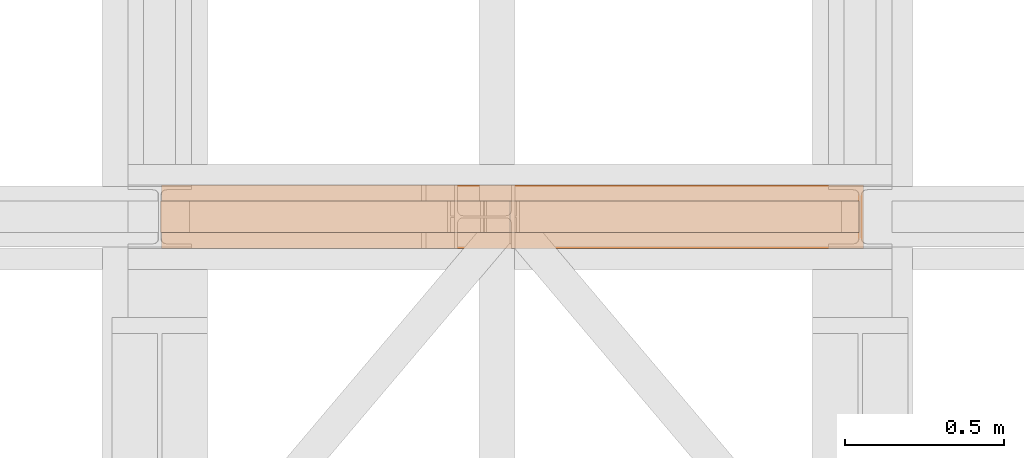
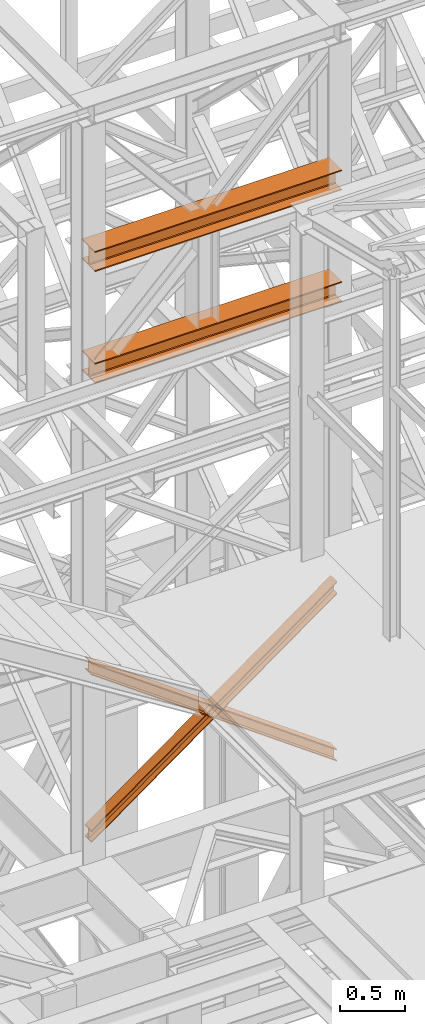
# One storey, part 109 of 208: 4 proxies.
"""IFC2X3 building model written with IfcOpenShell, lengths in millimetres."""

from ifc_helpers import new_model, entity, si_unit, converted_unit, frame, origin, origin_with_axes, place, context, subcontext, project, spatial, faceted_brep, element, save


model = new_model("IFC2X3")

# Units and contexts
model_context = context("Model", 3, precision=1e-05, world=origin())
plan_context = context("Plan", 3, precision=1e-05, world=origin())
body_context = subcontext(model_context, "Body", "Model", "MODEL_VIEW")
ifc_project = project(units=[si_unit("LENGTHUNIT", "METRE", prefix="MILLI"), converted_unit("PLANEANGLEUNIT", "DEGREE", entity("IfcPlaneAngleMeasure", 0.0174532925199433), si_unit("PLANEANGLEUNIT", "RADIAN"), dimensions=[0, 0, 0, 0, 0, 0, 0]), si_unit("AREAUNIT", "SQUARE_METRE"), si_unit("VOLUMEUNIT", "CUBIC_METRE")], contexts=[model_context, plan_context])

# Building, storey
building_placement = place(None, origin())
building = spatial("IfcBuilding", under=ifc_project, at=building_placement, CompositionType="COMPLEX")
storey_placement = place(building_placement, origin_with_axes())
storey = spatial("IfcBuildingStorey", under=building, at=storey_placement, Name="Geschoss", CompositionType="ELEMENT")

# Proxies
proxy_1_placement = place(storey_placement, frame((-4.245031471322136, -16012.57439031789, 5434.990005364418), z_axis=(0.0, 0.0, 1.0), x_axis=(1.0, 0.0, 0.0)))
element("IfcBuildingElementProxy", 1, at=proxy_1_placement, inside=storey, context=body_context, shape_type="Brep", body=[
    faceted_brep([(2194.25999993293, 0.01000000000021828, 1583.81921929576), (0.009999999999990905, 0.01000000000021828, 0.01000000000112777), (0.009999999999990905, 0.01000000000021828, 9.69256505868816), (2194.25999993293, 0.01000000000021828, 1593.501784354445), (2194.25999993293, 100.0100000000002, 1583.819219295759), (0.009999999999990905, 100.0100000000002, 0.01000000000021828), (0.009999999999990905, 0.01000000000021828, 0.01000000000112777), (2194.25999993293, 0.01000000000021828, 1583.81921929576), (2194.25999993293, 100.0100000000002, 1593.501784354445), (0.009999999999990905, 100.0100000000002, 9.69256505868816), (0.009999999999990905, 100.0100000000002, 0.01000000000021828), (2194.25999993293, 100.0100000000002, 1583.819219295759), (2194.25999993293, 52.51000000000022, 1593.501784354445), (0.009999999999990905, 52.51000000000022, 9.69256505868816), (0.009999999999990905, 100.0100000000002, 9.69256505868816), (2194.25999993293, 100.0100000000002, 1593.501784354445), (2194.259999932929, 52.51000000000022, 1690.327434941312), (0.009999999999990905, 52.51000000000022, 106.5182156455558), (0.009999999999990905, 52.51000000000022, 9.69256505868816), (2194.25999993293, 52.51000000000022, 1593.501784354445), (2194.25999993293, 100.0100000000002, 1690.327434941312), (0.01000000000180989, 100.0100000000002, 106.5182156455558), (0.009999999999990905, 52.51000000000022, 106.5182156455558), (2194.259999932929, 52.51000000000022, 1690.327434941312), (2194.25999993293, 100.0100000000002, 1700.01), (0.009999999999990905, 100.0100000000002, 116.2007807042428), (0.01000000000180989, 100.0100000000002, 106.5182156455558), (2194.25999993293, 100.0100000000002, 1690.327434941312), (2194.259999932929, 0.01000000000021828, 1700.01), (0.009999999999990905, 0.01000000000021828, 116.2007807042428), (0.009999999999990905, 100.0100000000002, 116.2007807042428), (2194.25999993293, 100.0100000000002, 1700.01), (2194.25999993293, 0.01000000000021828, 1690.327434941312), (0.009999999999990905, 0.01000000000021828, 106.5182156455549), (0.009999999999990905, 0.01000000000021828, 116.2007807042428), (2194.259999932929, 0.01000000000021828, 1700.01), (2194.25999993293, 47.51000000000022, 1690.327434941311), (0.009999999999990905, 47.51000000000022, 106.5182156455549), (0.009999999999990905, 0.01000000000021828, 106.5182156455549), (2194.25999993293, 0.01000000000021828, 1690.327434941312), (2194.25999993293, 47.51000000000022, 1593.501784354445), (0.009999999999990905, 47.51000000000022, 9.69256505868816), (0.009999999999990905, 47.51000000000022, 106.5182156455549), (2194.25999993293, 47.51000000000022, 1690.327434941311), (2194.25999993293, 0.01000000000021828, 1593.501784354445), (0.009999999999990905, 0.01000000000021828, 9.69256505868816), (0.009999999999990905, 47.51000000000022, 9.69256505868816), (2194.25999993293, 47.51000000000022, 1593.501784354445), (2194.25999993293, 0.01000000000021828, 1593.501784354445), (2194.25999993293, 47.51000000000022, 1593.501784354445), (2194.25999993293, 47.51000000000022, 1690.327434941311), (2194.25999993293, 0.01000000000021828, 1690.327434941312), (2194.259999932929, 0.01000000000021828, 1700.01), (2194.25999993293, 100.0100000000002, 1700.01), (2194.25999993293, 100.0100000000002, 1690.327434941312), (2194.259999932929, 52.51000000000022, 1690.327434941312), (2194.25999993293, 52.51000000000022, 1593.501784354445), (2194.25999993293, 100.0100000000002, 1593.501784354445), (2194.25999993293, 100.0100000000002, 1583.819219295759), (2194.25999993293, 0.01000000000021828, 1583.81921929576), (0.009999999999990905, 0.01000000000021828, 0.01000000000112777), (0.009999999999990905, 100.0100000000002, 0.01000000000021828), (0.009999999999990905, 100.0100000000002, 9.69256505868816), (0.009999999999990905, 52.51000000000022, 9.69256505868816), (0.009999999999990905, 52.51000000000022, 106.5182156455558), (0.01000000000180989, 100.0100000000002, 106.5182156455558), (0.009999999999990905, 100.0100000000002, 116.2007807042428), (0.009999999999990905, 0.01000000000021828, 116.2007807042428), (0.009999999999990905, 0.01000000000021828, 106.5182156455549), (0.009999999999990905, 47.51000000000022, 106.5182156455549), (0.009999999999990905, 47.51000000000022, 9.69256505868816), (0.009999999999990905, 0.01000000000021828, 9.69256505868816)], [[[0, 1, 2, 3]], [[4, 5, 6, 7]], [[8, 9, 10, 11]], [[12, 13, 14, 15]], [[16, 17, 18, 19]], [[20, 21, 22, 23]], [[24, 25, 26, 27]], [[28, 29, 30, 31]], [[32, 33, 34, 35]], [[36, 37, 38, 39]], [[40, 41, 42, 43]], [[44, 45, 46, 47]], [[48, 49, 50, 51, 52, 53, 54, 55, 56, 57, 58, 59]], [[60, 61, 62, 63, 64, 65, 66, 67, 68, 69, 70, 71]]], orient=[[False], [False], [False], [False], [False], [False], [False], [False], [False], [False], [False], [False], [False], [False]]),
])
proxy_2_placement = place(storey_placement, frame((-4.245031471322136, -16012.57439031789, 5434.990005364418), z_axis=(0.0, 0.0, 1.0), x_axis=(1.0, 0.0, 0.0)))
element("IfcBuildingElementProxy", 2, at=proxy_2_placement, inside=storey, context=body_context, shape_type="Brep", body=[
    faceted_brep([(0.009999999999990905, 0.01000000000021828, 1593.501784354445), (2194.25999993293, 0.01000000000021828, 9.692565058686341), (2194.25999993293, 0.01000000000021828, 0.01000000000112777), (0.009999999999990905, 0.01000000000021828, 1583.819219295759), (0.009999999999990905, 0.01000000000021828, 1583.819219295759), (2194.25999993293, 0.01000000000021828, 0.01000000000112777), (2194.25999993293, 100.0100000000002, 0.01000000000021828), (0.009999999999990905, 100.0100000000002, 1583.819219295759), (0.009999999999990905, 100.0100000000002, 1583.819219295759), (2194.25999993293, 100.0100000000002, 0.01000000000021828), (2194.25999993293, 100.0100000000002, 9.692565058686341), (0.009999999999990905, 100.0100000000002, 1593.501784354445), (0.009999999999990905, 100.0100000000002, 1593.501784354445), (2194.25999993293, 100.0100000000002, 9.692565058686341), (2194.25999993293, 52.51000000000022, 9.692565058686341), (0.009999999999990905, 52.51000000000022, 1593.501784354445), (0.009999999999990905, 52.51000000000022, 1593.501784354445), (2194.25999993293, 52.51000000000022, 9.692565058686341), (2194.259999932929, 52.51000000000022, 106.5182156455549), (0.009999999999990905, 52.51000000000022, 1690.327434941313), (0.009999999999990905, 52.51000000000022, 1690.327434941313), (2194.259999932929, 52.51000000000022, 106.5182156455549), (2194.25999993293, 100.0100000000002, 106.5182156455549), (0.009999999999990905, 100.0100000000002, 1690.327434941311), (0.009999999999990905, 100.0100000000002, 1690.327434941311), (2194.25999993293, 100.0100000000002, 106.5182156455549), (2194.259999932929, 100.0100000000002, 116.2007807042419), (0.009999999999990905, 100.0100000000002, 1700.01), (0.009999999999990905, 100.0100000000002, 1700.01), (2194.259999932929, 100.0100000000002, 116.2007807042419), (2194.25999993293, 0.01000000000021828, 116.2007807042419), (0.009999999999990905, 0.01000000000021828, 1700.01), (0.009999999999990905, 0.01000000000021828, 1700.01), (2194.25999993293, 0.01000000000021828, 116.2007807042419), (2194.25999993293, 0.01000000000021828, 106.5182156455549), (0.009999999999990905, 0.01000000000021828, 1690.327434941313), (0.009999999999990905, 0.01000000000021828, 1690.327434941313), (2194.25999993293, 0.01000000000021828, 106.5182156455549), (2194.25999993293, 47.51000000000022, 106.5182156455539), (0.009999999999990905, 47.51000000000022, 1690.327434941311), (0.009999999999990905, 47.51000000000022, 1690.327434941311), (2194.25999993293, 47.51000000000022, 106.5182156455539), (2194.25999993293, 47.51000000000022, 9.692565058686341), (0.009999999999990905, 47.51000000000022, 1593.501784354445), (0.009999999999990905, 47.51000000000022, 1593.501784354445), (2194.25999993293, 47.51000000000022, 9.692565058686341), (2194.25999993293, 0.01000000000021828, 9.692565058686341), (0.009999999999990905, 0.01000000000021828, 1593.501784354445), (2194.25999993293, 0.01000000000021828, 9.692565058686341), (2194.25999993293, 47.51000000000022, 9.692565058686341), (2194.25999993293, 47.51000000000022, 106.5182156455539), (2194.25999993293, 0.01000000000021828, 106.5182156455549), (2194.25999993293, 0.01000000000021828, 116.2007807042419), (2194.259999932929, 100.0100000000002, 116.2007807042419), (2194.25999993293, 100.0100000000002, 106.5182156455549), (2194.259999932929, 52.51000000000022, 106.5182156455549), (2194.25999993293, 52.51000000000022, 9.692565058686341), (2194.25999993293, 100.0100000000002, 9.692565058686341), (2194.25999993293, 100.0100000000002, 0.01000000000021828), (2194.25999993293, 0.01000000000021828, 0.01000000000112777), (0.009999999999990905, 0.01000000000021828, 1583.819219295759), (0.009999999999990905, 100.0100000000002, 1583.819219295759), (0.009999999999990905, 100.0100000000002, 1593.501784354445), (0.009999999999990905, 52.51000000000022, 1593.501784354445), (0.009999999999990905, 52.51000000000022, 1690.327434941313), (0.009999999999990905, 100.0100000000002, 1690.327434941311), (0.009999999999990905, 100.0100000000002, 1700.01), (0.009999999999990905, 0.01000000000021828, 1700.01), (0.009999999999990905, 0.01000000000021828, 1690.327434941313), (0.009999999999990905, 47.51000000000022, 1690.327434941311), (0.009999999999990905, 47.51000000000022, 1593.501784354445), (0.009999999999990905, 0.01000000000021828, 1593.501784354445)], [[[0, 1, 2, 3]], [[4, 5, 6, 7]], [[8, 9, 10, 11]], [[12, 13, 14, 15]], [[16, 17, 18, 19]], [[20, 21, 22, 23]], [[24, 25, 26, 27]], [[28, 29, 30, 31]], [[32, 33, 34, 35]], [[36, 37, 38, 39]], [[40, 41, 42, 43]], [[44, 45, 46, 47]], [[48, 49, 50, 51, 52, 53, 54, 55, 56, 57, 58, 59]], [[60, 61, 62, 63, 64, 65, 66, 67, 68, 69, 70, 71]]], orient=[[False], [False], [False], [False], [False], [False], [False], [False], [False], [False], [False], [False], [False], [False]]),
])
proxy_3_placement = place(storey_placement, frame((-1.630483097365641, -16062.574391808, 10858.99004617683), z_axis=(0.0, 0.0, 1.0), x_axis=(1.0, 0.0, 0.0)))
element("IfcBuildingElementProxy", 3, at=proxy_3_placement, inside=storey, context=body_context, shape_type="Brep", body=[
    faceted_brep([(0.009999999999990905, 0.01000000000021828, 0.01000000000021828), (0.009999999999990905, 200.0100029802325, 0.01000000000021828), (0.009999999999990905, 200.0100029802325, 10.00999791383765), (0.009999999999990905, 121.2600035762789, 10.01000536441825), (0.009999999999990905, 111.9441915473344, 11.87455041170142), (0.009999999999990905, 105.1245498640838, 18.69419349193595), (0.009999999999990905, 103.2600015571716, 28.01000458955787), (0.009999999999990905, 103.2600015571716, 162.0100153779986), (0.009999999999990905, 105.1245498640838, 171.3258264756205), (0.009999999999990905, 111.9441915473344, 178.145469555855), (0.009999999999990905, 121.2600035762789, 180.0100146031382), (0.009999999999990905, 200.0100029802325, 180.0100146031382), (0.009999999999990905, 200.0100029802325, 190.0100125169756), (0.009999999999990905, 0.01000000000021828, 190.0100125169756), (0.009999999999990905, 0.01000000000021828, 180.0100146031382), (0.009999999999990905, 78.75999940395377, 180.0100146031382), (0.009999999999990905, 88.07581143289826, 178.145469555855), (0.009999999999990905, 94.89545311614893, 171.3258264756205), (0.009999999999990905, 96.76000142306111, 162.0100153779986), (0.009999999999990905, 96.76000142306111, 28.01000458955787), (0.009999999999990905, 94.89545311614893, 18.69419349193595), (0.009999999999990905, 88.07581143289826, 11.87455041170142), (0.009999999999990905, 78.75999940395377, 10.01000536441825), (0.009999999999990905, 0.01000000000021828, 10.00999791383765), (0.009999999999990905, 200.0100029802325, 0.01000000000021828), (0.009999999999990905, 0.01000000000021828, 0.01000000000021828), (2205.009999999998, 0.00999999999839929, 0.01000000000021828), (2205.009999999998, 200.0100029802306, 0.01000000000021828), (0.009999999999990905, 200.0100029802325, 10.00999791383765), (0.009999999999990905, 200.0100029802325, 0.01000000000021828), (2205.009999999998, 200.0100029802306, 0.01000000000021828), (2205.009999999998, 200.0100029802306, 10.00999791383765), (0.009999999999990905, 121.2600035762789, 10.01000536441825), (0.009999999999990905, 200.0100029802325, 10.00999791383765), (2205.009999999998, 200.0100029802306, 10.00999791383765), (2205.009999999998, 121.2600035762771, 10.01000536441825), (0.009999999999990905, 111.9441915473344, 11.87455041170142), (0.009999999999990905, 121.2600035762789, 10.01000536441825), (2205.009999999998, 121.2600035762771, 10.01000536441825), (2205.009999999998, 111.9441915473326, 11.87455041170142), (0.009999999999990905, 105.1245498640838, 18.69419349193595), (0.009999999999990905, 111.9441915473344, 11.87455041170142), (2205.009999999998, 111.9441915473326, 11.87455041170142), (2205.009999999998, 105.1245498640819, 18.69419349193595), (0.009999999999990905, 103.2600015571716, 28.01000458955787), (0.009999999999990905, 105.1245498640838, 18.69419349193595), (2205.009999999998, 105.1245498640819, 18.69419349193595), (2205.009999999998, 103.2600015571697, 28.01000458955787), (0.009999999999990905, 103.2600015571716, 162.0100153779986), (0.009999999999990905, 103.2600015571716, 28.01000458955787), (2205.009999999998, 103.2600015571697, 28.01000458955787), (2205.009999999998, 103.2600015571697, 162.0100153779986), (0.009999999999990905, 105.1245498640838, 171.3258264756205), (0.009999999999990905, 103.2600015571716, 162.0100153779986), (2205.009999999998, 103.2600015571697, 162.0100153779986), (2205.009999999998, 105.1245498640819, 171.3258264756205), (0.009999999999990905, 111.9441915473344, 178.145469555855), (0.009999999999990905, 105.1245498640838, 171.3258264756205), (2205.009999999998, 105.1245498640819, 171.3258264756205), (2205.009999999998, 111.9441915473326, 178.145469555855), (0.009999999999990905, 121.2600035762789, 180.0100146031382), (0.009999999999990905, 111.9441915473344, 178.145469555855), (2205.009999999998, 111.9441915473326, 178.145469555855), (2205.009999999998, 121.2600035762771, 180.0100146031382), (0.009999999999990905, 200.0100029802325, 180.0100146031382), (0.009999999999990905, 121.2600035762789, 180.0100146031382), (2205.009999999998, 121.2600035762771, 180.0100146031382), (2205.009999999998, 200.0100029802306, 180.0100146031382), (0.009999999999990905, 200.0100029802325, 190.0100125169756), (0.009999999999990905, 200.0100029802325, 180.0100146031382), (2205.009999999998, 200.0100029802306, 180.0100146031382), (2205.009999999998, 200.0100029802306, 190.0100125169756), (0.009999999999990905, 0.01000000000021828, 190.0100125169756), (0.009999999999990905, 200.0100029802325, 190.0100125169756), (2205.009999999998, 200.0100029802306, 190.0100125169756), (2205.009999999998, 0.00999999999839929, 190.0100125169756), (0.009999999999990905, 0.01000000000021828, 180.0100146031382), (0.009999999999990905, 0.01000000000021828, 190.0100125169756), (2205.009999999998, 0.00999999999839929, 190.0100125169756), (2205.009999999998, 0.00999999999839929, 180.0100146031382), (0.009999999999990905, 78.75999940395377, 180.0100146031382), (0.009999999999990905, 0.01000000000021828, 180.0100146031382), (2205.009999999998, 0.00999999999839929, 180.0100146031382), (2205.009999999998, 78.75999940395195, 180.0100146031382), (0.009999999999990905, 88.07581143289826, 178.145469555855), (0.009999999999990905, 78.75999940395377, 180.0100146031382), (2205.009999999998, 78.75999940395195, 180.0100146031382), (2205.009999999998, 88.07581143289644, 178.145469555855), (0.009999999999990905, 94.89545311614893, 171.3258264756205), (0.009999999999990905, 88.07581143289826, 178.145469555855), (2205.009999999998, 88.07581143289644, 178.145469555855), (2205.009999999998, 94.89545311614711, 171.3258264756205), (0.009999999999990905, 96.76000142306111, 162.0100153779986), (0.009999999999990905, 94.89545311614893, 171.3258264756205), (2205.009999999998, 94.89545311614711, 171.3258264756205), (2205.009999999998, 96.7600014230593, 162.0100153779986), (0.009999999999990905, 96.76000142306111, 28.01000458955787), (0.009999999999990905, 96.76000142306111, 162.0100153779986), (2205.009999999998, 96.7600014230593, 162.0100153779986), (2205.009999999998, 96.7600014230593, 28.01000458955787), (0.009999999999990905, 94.89545311614893, 18.69419349193595), (0.009999999999990905, 96.76000142306111, 28.01000458955787), (2205.009999999998, 96.7600014230593, 28.01000458955787), (2205.009999999998, 94.89545311614711, 18.69419349193595), (0.009999999999990905, 88.07581143289826, 11.87455041170142), (0.009999999999990905, 94.89545311614893, 18.69419349193595), (2205.009999999998, 94.89545311614711, 18.69419349193595), (2205.009999999998, 88.07581143289644, 11.87455041170142), (0.009999999999990905, 78.75999940395377, 10.01000536441825), (0.009999999999990905, 88.07581143289826, 11.87455041170142), (2205.009999999998, 88.07581143289644, 11.87455041170142), (2205.009999999998, 78.75999940395195, 10.01000536441825), (0.009999999999990905, 0.01000000000021828, 10.00999791383765), (0.009999999999990905, 78.75999940395377, 10.01000536441825), (2205.009999999998, 78.75999940395195, 10.01000536441825), (2205.009999999998, 0.00999999999839929, 10.00999791383765), (0.009999999999990905, 0.01000000000021828, 0.01000000000021828), (0.009999999999990905, 0.01000000000021828, 10.00999791383765), (2205.009999999998, 0.00999999999839929, 10.00999791383765), (2205.009999999998, 0.00999999999839929, 0.01000000000021828), (2205.009999999998, 0.00999999999839929, 0.01000000000021828), (2205.009999999998, 0.00999999999839929, 10.00999791383765), (2205.009999999998, 78.75999940395195, 10.01000536441825), (2205.009999999998, 88.07581143289644, 11.87455041170142), (2205.009999999998, 94.89545311614711, 18.69419349193595), (2205.009999999998, 96.7600014230593, 28.01000458955787), (2205.009999999998, 96.7600014230593, 162.0100153779986), (2205.009999999998, 94.89545311614711, 171.3258264756205), (2205.009999999998, 88.07581143289644, 178.145469555855), (2205.009999999998, 78.75999940395195, 180.0100146031382), (2205.009999999998, 0.00999999999839929, 180.0100146031382), (2205.009999999998, 0.00999999999839929, 190.0100125169756), (2205.009999999998, 200.0100029802306, 190.0100125169756), (2205.009999999998, 200.0100029802306, 180.0100146031382), (2205.009999999998, 121.2600035762771, 180.0100146031382), (2205.009999999998, 111.9441915473326, 178.145469555855), (2205.009999999998, 105.1245498640819, 171.3258264756205), (2205.009999999998, 103.2600015571697, 162.0100153779986), (2205.009999999998, 103.2600015571697, 28.01000458955787), (2205.009999999998, 105.1245498640819, 18.69419349193595), (2205.009999999998, 111.9441915473326, 11.87455041170142), (2205.009999999998, 121.2600035762771, 10.01000536441825), (2205.009999999998, 200.0100029802306, 10.00999791383765), (2205.009999999998, 200.0100029802306, 0.01000000000021828)], [[[0, 1, 2, 3, 4, 5, 6, 7, 8, 9, 10, 11, 12, 13, 14, 15, 16, 17, 18, 19, 20, 21, 22, 23]], [[24, 25, 26, 27]], [[28, 29, 30, 31]], [[32, 33, 34, 35]], [[36, 37, 38, 39]], [[40, 41, 42, 43]], [[44, 45, 46, 47]], [[48, 49, 50, 51]], [[52, 53, 54, 55]], [[56, 57, 58, 59]], [[60, 61, 62, 63]], [[64, 65, 66, 67]], [[68, 69, 70, 71]], [[72, 73, 74, 75]], [[76, 77, 78, 79]], [[80, 81, 82, 83]], [[84, 85, 86, 87]], [[88, 89, 90, 91]], [[92, 93, 94, 95]], [[96, 97, 98, 99]], [[100, 101, 102, 103]], [[104, 105, 106, 107]], [[108, 109, 110, 111]], [[112, 113, 114, 115]], [[116, 117, 118, 119]], [[120, 121, 122, 123, 124, 125, 126, 127, 128, 129, 130, 131, 132, 133, 134, 135, 136, 137, 138, 139, 140, 141, 142, 143]]], orient=[[False], [False], [False], [False], [False], [False], [False], [False], [False], [False], [False], [False], [False], [False], [False], [False], [False], [False], [False], [False], [False], [False], [False], [False], [False], [False]]),
])
proxy_4_placement = place(storey_placement, frame((-1.630483097365641, -16062.574391808, 9803.990033659858), z_axis=(0.0, 0.0, 1.0), x_axis=(1.0, 0.0, 0.0)))
element("IfcBuildingElementProxy", 4, at=proxy_4_placement, inside=storey, context=body_context, shape_type="Brep", body=[
    faceted_brep([(0.009999999999990905, 0.01000000000021828, 0.01000000000021828), (0.009999999999990905, 200.0100029802325, 0.01000000000021828), (0.009999999999990905, 200.0100029802325, 10.00999791383765), (0.009999999999990905, 121.2600035762789, 10.01000536441825), (0.009999999999990905, 111.9441915473344, 11.87455041170142), (0.009999999999990905, 105.1245498640838, 18.69419349193595), (0.009999999999990905, 103.2600015571716, 28.01000458955787), (0.009999999999990905, 103.2600015571716, 162.0100153779986), (0.009999999999990905, 105.1245498640838, 171.3258264756205), (0.009999999999990905, 111.9441915473344, 178.145469555855), (0.009999999999990905, 121.2600035762789, 180.0100146031382), (0.009999999999990905, 200.0100029802325, 180.0100146031382), (0.009999999999990905, 200.0100029802325, 190.0100125169756), (0.009999999999990905, 0.01000000000021828, 190.0100125169756), (0.009999999999990905, 0.01000000000021828, 180.0100146031382), (0.009999999999990905, 78.75999940395377, 180.0100146031382), (0.009999999999990905, 88.07581143289826, 178.145469555855), (0.009999999999990905, 94.89545311614893, 171.3258264756205), (0.009999999999990905, 96.76000142306111, 162.0100153779986), (0.009999999999990905, 96.76000142306111, 28.01000458955787), (0.009999999999990905, 94.89545311614893, 18.69419349193595), (0.009999999999990905, 88.07581143289826, 11.87455041170142), (0.009999999999990905, 78.75999940395377, 10.01000536441825), (0.009999999999990905, 0.01000000000021828, 10.00999791383765), (0.009999999999990905, 200.0100029802325, 0.01000000000021828), (0.009999999999990905, 0.01000000000021828, 0.01000000000021828), (2205.009999999998, 0.00999999999839929, 0.01000000000021828), (2205.009999999998, 200.0100029802306, 0.01000000000021828), (0.009999999999990905, 200.0100029802325, 10.00999791383765), (0.009999999999990905, 200.0100029802325, 0.01000000000021828), (2205.009999999998, 200.0100029802306, 0.01000000000021828), (2205.009999999998, 200.0100029802306, 10.00999791383765), (0.009999999999990905, 121.2600035762789, 10.01000536441825), (0.009999999999990905, 200.0100029802325, 10.00999791383765), (2205.009999999998, 200.0100029802306, 10.00999791383765), (2205.009999999998, 121.2600035762771, 10.01000536441825), (0.009999999999990905, 111.9441915473344, 11.87455041170142), (0.009999999999990905, 121.2600035762789, 10.01000536441825), (2205.009999999998, 121.2600035762771, 10.01000536441825), (2205.009999999998, 111.9441915473326, 11.87455041170142), (0.009999999999990905, 105.1245498640838, 18.69419349193595), (0.009999999999990905, 111.9441915473344, 11.87455041170142), (2205.009999999998, 111.9441915473326, 11.87455041170142), (2205.009999999998, 105.1245498640819, 18.69419349193595), (0.009999999999990905, 103.2600015571716, 28.01000458955787), (0.009999999999990905, 105.1245498640838, 18.69419349193595), (2205.009999999998, 105.1245498640819, 18.69419349193595), (2205.009999999998, 103.2600015571697, 28.01000458955787), (0.009999999999990905, 103.2600015571716, 162.0100153779986), (0.009999999999990905, 103.2600015571716, 28.01000458955787), (2205.009999999998, 103.2600015571697, 28.01000458955787), (2205.009999999998, 103.2600015571697, 162.0100153779986), (0.009999999999990905, 105.1245498640838, 171.3258264756205), (0.009999999999990905, 103.2600015571716, 162.0100153779986), (2205.009999999998, 103.2600015571697, 162.0100153779986), (2205.009999999998, 105.1245498640819, 171.3258264756205), (0.009999999999990905, 111.9441915473344, 178.145469555855), (0.009999999999990905, 105.1245498640838, 171.3258264756205), (2205.009999999998, 105.1245498640819, 171.3258264756205), (2205.009999999998, 111.9441915473326, 178.145469555855), (0.009999999999990905, 121.2600035762789, 180.0100146031382), (0.009999999999990905, 111.9441915473344, 178.145469555855), (2205.009999999998, 111.9441915473326, 178.145469555855), (2205.009999999998, 121.2600035762771, 180.0100146031382), (0.009999999999990905, 200.0100029802325, 180.0100146031382), (0.009999999999990905, 121.2600035762789, 180.0100146031382), (2205.009999999998, 121.2600035762771, 180.0100146031382), (2205.009999999998, 200.0100029802306, 180.0100146031382), (0.009999999999990905, 200.0100029802325, 190.0100125169756), (0.009999999999990905, 200.0100029802325, 180.0100146031382), (2205.009999999998, 200.0100029802306, 180.0100146031382), (2205.009999999998, 200.0100029802306, 190.0100125169756), (0.009999999999990905, 0.01000000000021828, 190.0100125169756), (0.009999999999990905, 200.0100029802325, 190.0100125169756), (2205.009999999998, 200.0100029802306, 190.0100125169756), (2205.009999999998, 0.00999999999839929, 190.0100125169756), (0.009999999999990905, 0.01000000000021828, 180.0100146031382), (0.009999999999990905, 0.01000000000021828, 190.0100125169756), (2205.009999999998, 0.00999999999839929, 190.0100125169756), (2205.009999999998, 0.00999999999839929, 180.0100146031382), (0.009999999999990905, 78.75999940395377, 180.0100146031382), (0.009999999999990905, 0.01000000000021828, 180.0100146031382), (2205.009999999998, 0.00999999999839929, 180.0100146031382), (2205.009999999998, 78.75999940395195, 180.0100146031382), (0.009999999999990905, 88.07581143289826, 178.145469555855), (0.009999999999990905, 78.75999940395377, 180.0100146031382), (2205.009999999998, 78.75999940395195, 180.0100146031382), (2205.009999999998, 88.07581143289644, 178.145469555855), (0.009999999999990905, 94.89545311614893, 171.3258264756205), (0.009999999999990905, 88.07581143289826, 178.145469555855), (2205.009999999998, 88.07581143289644, 178.145469555855), (2205.009999999998, 94.89545311614711, 171.3258264756205), (0.009999999999990905, 96.76000142306111, 162.0100153779986), (0.009999999999990905, 94.89545311614893, 171.3258264756205), (2205.009999999998, 94.89545311614711, 171.3258264756205), (2205.009999999998, 96.7600014230593, 162.0100153779986), (0.009999999999990905, 96.76000142306111, 28.01000458955787), (0.009999999999990905, 96.76000142306111, 162.0100153779986), (2205.009999999998, 96.7600014230593, 162.0100153779986), (2205.009999999998, 96.7600014230593, 28.01000458955787), (0.009999999999990905, 94.89545311614893, 18.69419349193595), (0.009999999999990905, 96.76000142306111, 28.01000458955787), (2205.009999999998, 96.7600014230593, 28.01000458955787), (2205.009999999998, 94.89545311614711, 18.69419349193595), (0.009999999999990905, 88.07581143289826, 11.87455041170142), (0.009999999999990905, 94.89545311614893, 18.69419349193595), (2205.009999999998, 94.89545311614711, 18.69419349193595), (2205.009999999998, 88.07581143289644, 11.87455041170142), (0.009999999999990905, 78.75999940395377, 10.01000536441825), (0.009999999999990905, 88.07581143289826, 11.87455041170142), (2205.009999999998, 88.07581143289644, 11.87455041170142), (2205.009999999998, 78.75999940395195, 10.01000536441825), (0.009999999999990905, 0.01000000000021828, 10.00999791383765), (0.009999999999990905, 78.75999940395377, 10.01000536441825), (2205.009999999998, 78.75999940395195, 10.01000536441825), (2205.009999999998, 0.00999999999839929, 10.00999791383765), (0.009999999999990905, 0.01000000000021828, 0.01000000000021828), (0.009999999999990905, 0.01000000000021828, 10.00999791383765), (2205.009999999998, 0.00999999999839929, 10.00999791383765), (2205.009999999998, 0.00999999999839929, 0.01000000000021828), (2205.009999999998, 0.00999999999839929, 0.01000000000021828), (2205.009999999998, 0.00999999999839929, 10.00999791383765), (2205.009999999998, 78.75999940395195, 10.01000536441825), (2205.009999999998, 88.07581143289644, 11.87455041170142), (2205.009999999998, 94.89545311614711, 18.69419349193595), (2205.009999999998, 96.7600014230593, 28.01000458955787), (2205.009999999998, 96.7600014230593, 162.0100153779986), (2205.009999999998, 94.89545311614711, 171.3258264756205), (2205.009999999998, 88.07581143289644, 178.145469555855), (2205.009999999998, 78.75999940395195, 180.0100146031382), (2205.009999999998, 0.00999999999839929, 180.0100146031382), (2205.009999999998, 0.00999999999839929, 190.0100125169756), (2205.009999999998, 200.0100029802306, 190.0100125169756), (2205.009999999998, 200.0100029802306, 180.0100146031382), (2205.009999999998, 121.2600035762771, 180.0100146031382), (2205.009999999998, 111.9441915473326, 178.145469555855), (2205.009999999998, 105.1245498640819, 171.3258264756205), (2205.009999999998, 103.2600015571697, 162.0100153779986), (2205.009999999998, 103.2600015571697, 28.01000458955787), (2205.009999999998, 105.1245498640819, 18.69419349193595), (2205.009999999998, 111.9441915473326, 11.87455041170142), (2205.009999999998, 121.2600035762771, 10.01000536441825), (2205.009999999998, 200.0100029802306, 10.00999791383765), (2205.009999999998, 200.0100029802306, 0.01000000000021828)], [[[0, 1, 2, 3, 4, 5, 6, 7, 8, 9, 10, 11, 12, 13, 14, 15, 16, 17, 18, 19, 20, 21, 22, 23]], [[24, 25, 26, 27]], [[28, 29, 30, 31]], [[32, 33, 34, 35]], [[36, 37, 38, 39]], [[40, 41, 42, 43]], [[44, 45, 46, 47]], [[48, 49, 50, 51]], [[52, 53, 54, 55]], [[56, 57, 58, 59]], [[60, 61, 62, 63]], [[64, 65, 66, 67]], [[68, 69, 70, 71]], [[72, 73, 74, 75]], [[76, 77, 78, 79]], [[80, 81, 82, 83]], [[84, 85, 86, 87]], [[88, 89, 90, 91]], [[92, 93, 94, 95]], [[96, 97, 98, 99]], [[100, 101, 102, 103]], [[104, 105, 106, 107]], [[108, 109, 110, 111]], [[112, 113, 114, 115]], [[116, 117, 118, 119]], [[120, 121, 122, 123, 124, 125, 126, 127, 128, 129, 130, 131, 132, 133, 134, 135, 136, 137, 138, 139, 140, 141, 142, 143]]], orient=[[False], [False], [False], [False], [False], [False], [False], [False], [False], [False], [False], [False], [False], [False], [False], [False], [False], [False], [False], [False], [False], [False], [False], [False], [False], [False]]),
])

save(model, "model.ifc")
